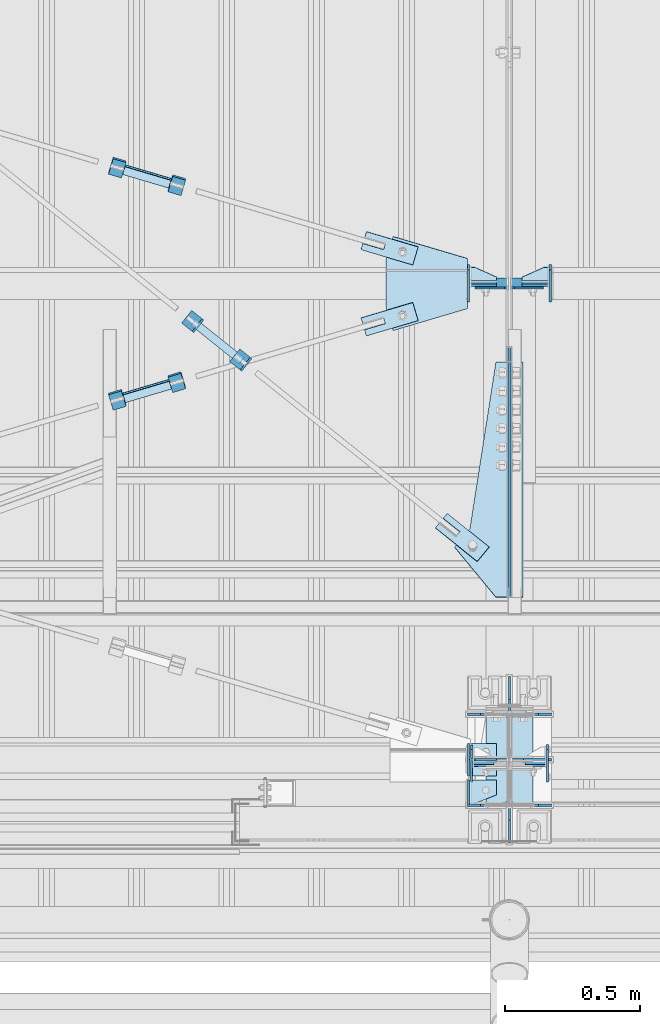
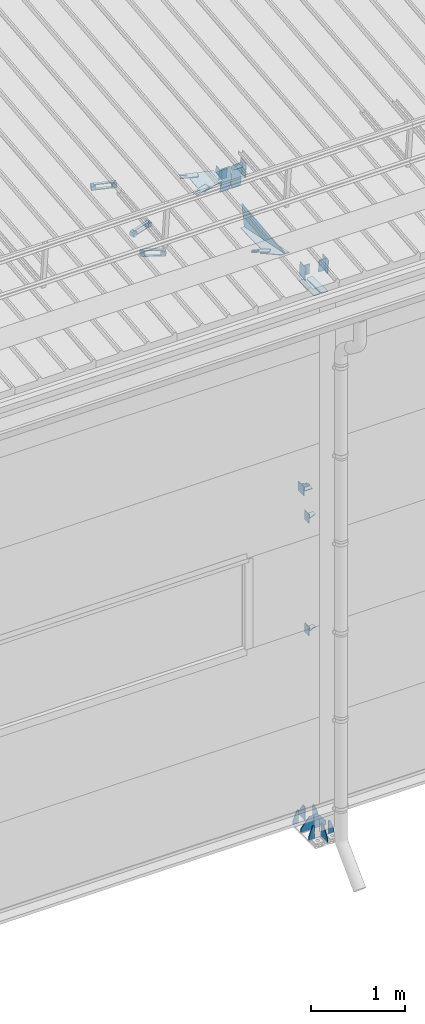
# One storey, part 147 of 709: 47 plates, 2 openings, 15 elements without a shape of their own.
"""IFC4 building model written with IfcOpenShell, lengths in millimetres."""

from ifc_helpers import new_model, si_unit, direction, frame, origin_with_axes, place, context, subcontext, project, spatial, line, indexed_curve, outline, extrude, material, element, aggregate, save


model = new_model("IFC4")

# Units and contexts
model_context = context("Model", 3, precision=0.2, world=origin_with_axes(), true_north=direction((0.0, 1.0)))
body_context = subcontext(model_context, "Body", "Model", "MODEL_VIEW")
ifc_project = project(units=[si_unit("LENGTHUNIT", "METRE", prefix="MILLI"), si_unit("AREAUNIT", "SQUARE_METRE"), si_unit("VOLUMEUNIT", "CUBIC_METRE"), si_unit("MASSUNIT", "GRAM", prefix="KILO"), si_unit("TIMEUNIT", "SECOND"), si_unit("PLANEANGLEUNIT", "RADIAN"), si_unit("SOLIDANGLEUNIT", "STERADIAN"), si_unit("THERMODYNAMICTEMPERATUREUNIT", "DEGREE_CELSIUS"), si_unit("LUMINOUSINTENSITYUNIT", "LUMEN")], contexts=[model_context])

# Site, building, storey
site_placement = place(None, origin_with_axes())
site = spatial("IfcSite", under=ifc_project, at=site_placement, CompositionType="ELEMENT")
building_placement = place(site_placement, origin_with_axes())
building = spatial("IfcBuilding", under=site, at=building_placement, Name="Undefined", CompositionType="ELEMENT")
storey_placement = place(building_placement, origin_with_axes())
storey = spatial("IfcBuildingStorey", under=building, at=storey_placement, Name="Undefined", CompositionType="ELEMENT", Elevation=0.0)

# Assembly, plates
assembly_1_placement = place(storey_placement, frame((46000.0, 173.0, -200.0), z_axis=(-1.0, 0.0, 0.0), x_axis=(0.0, 0.0, 1.0)))
assembly_1 = element("IfcElementAssembly", 1, at=assembly_1_placement, inside=storey)
ifc_material_1 = material(Name="C355-6", Category="STEEL")
plate_1_placement = place(assembly_1_placement, frame((25.0, -168.5, -87.0), z_axis=(0.0, -1.0, 0.0), x_axis=(0.0, 0.0, -1.0)))
plate_1 = element("IfcPlate", 2, at=plate_1_placement, material=ifc_material_1, ObjectType="419", context=body_context, shape_type="SolidModel", body=[
    extrude(outline(indexed_curve([(0.0, 0.0), (68.0, 0.0), (68.0, 50.0), (20.0, 175.0), (0.0, 175.0)], segments=[line(1, 2, 3, 4, 5, 1)])), frame((0.0, 0.0, 4.0), z_axis=(0.0, 0.0, 1.0), x_axis=(1.0, 0.0, 0.0)), (0.0, 0.0, -1.0), 8.0),
])
plate_2_placement = place(assembly_1_placement, frame((25.0, 168.5, -87.0), z_axis=(0.0, -1.0, 0.0), x_axis=(0.0, 0.0, -1.0)))
plate_2 = element("IfcPlate", 3, at=plate_2_placement, material=ifc_material_1, ObjectType="419", context=body_context, shape_type="SolidModel", body=[
    extrude(outline(indexed_curve([(0.0, 0.0), (68.0, 0.0), (68.0, 50.0), (20.0, 175.0), (0.0, 175.0)], segments=[line(1, 2, 3, 4, 5, 1)])), frame((0.0, 0.0, 4.0), z_axis=(0.0, 0.0, 1.0), x_axis=(1.0, 0.0, 0.0)), (0.0, 0.0, -1.0), 8.0),
])
plate_3_placement = place(assembly_1_placement, frame((25.0, 168.5, 87.0), z_axis=(0.0, 1.0, 0.0), x_axis=(0.0, 0.0, 1.0)))
plate_3 = element("IfcPlate", 4, at=plate_3_placement, material=ifc_material_1, ObjectType="419", context=body_context, shape_type="SolidModel", body=[
    extrude(outline(indexed_curve([(0.0, 0.0), (68.0, 0.0), (68.0, 50.0), (20.0, 175.0), (0.0, 175.0)], segments=[line(1, 2, 3, 4, 5, 1)])), frame((0.0, 0.0, 4.0), z_axis=(0.0, 0.0, 1.0), x_axis=(1.0, 0.0, 0.0)), (0.0, 0.0, -1.0), 8.0),
])
plate_4_placement = place(assembly_1_placement, frame((25.0, -173.0, 0.0), z_axis=(0.0, 0.0, 1.0), x_axis=(0.0, -1.0, 0.0)))
plate_4 = element("IfcPlate", 5, at=plate_4_placement, material=ifc_material_1, ObjectType="418", context=body_context, shape_type="SolidModel", body=[
    extrude(outline(indexed_curve([(0.0, 0.0), (135.0, 0.0), (135.0, 50.0), (50.0, 175.0), (0.0, 175.0)], segments=[line(1, 2, 3, 4, 5, 1)])), frame((0.0, 0.0, 4.0), z_axis=(0.0, 0.0, 1.0), x_axis=(1.0, 0.0, 0.0)), (0.0, 0.0, -1.0), 8.0),
])
plate_5_placement = place(assembly_1_placement, frame((25.0, -168.5, 87.0), z_axis=(0.0, 1.0, 0.0), x_axis=(0.0, 0.0, 1.0)))
plate_5 = element("IfcPlate", 6, at=plate_5_placement, material=ifc_material_1, ObjectType="419", context=body_context, shape_type="SolidModel", body=[
    extrude(outline(indexed_curve([(0.0, 0.0), (68.0, 0.0), (68.0, 50.0), (20.0, 175.0), (0.0, 175.0)], segments=[line(1, 2, 3, 4, 5, 1)])), frame((0.0, 0.0, 4.0), z_axis=(0.0, 0.0, 1.0), x_axis=(1.0, 0.0, 0.0)), (0.0, 0.0, -1.0), 8.0),
])
plate_6_placement = place(assembly_1_placement, frame((25.0, 0.0, -3.0), z_axis=(0.0, -1.0, 0.0), x_axis=(0.0, 0.0, -1.0)))
plate_6 = element("IfcPlate", 7, at=plate_6_placement, material=ifc_material_1, ObjectType="417", context=body_context, shape_type="SolidModel", body=[
    extrude(outline(indexed_curve([(0.0, 0.0), (152.0, 0.0), (152.0, 50.0), (50.0, 175.0), (0.0, 175.0)], segments=[line(1, 2, 3, 4, 5, 1)])), frame((0.0, 0.0, 4.0), z_axis=(0.0, 0.0, 1.0), x_axis=(1.0, 0.0, 0.0)), (0.0, 0.0, -1.0), 8.0),
])
plate_7_placement = place(assembly_1_placement, frame((25.0, 0.0, 3.0), z_axis=(0.0, 1.0, 0.0), x_axis=(0.0, 0.0, 1.0)))
plate_7 = element("IfcPlate", 8, at=plate_7_placement, material=ifc_material_1, ObjectType="417", context=body_context, shape_type="SolidModel", body=[
    extrude(outline(indexed_curve([(0.0, 0.0), (152.0, 0.0), (152.0, 50.0), (50.0, 175.0), (0.0, 175.0)], segments=[line(1, 2, 3, 4, 5, 1)])), frame((0.0, 0.0, 4.0), z_axis=(0.0, 0.0, 1.0), x_axis=(1.0, 0.0, 0.0)), (0.0, 0.0, -1.0), 8.0),
])
plate_8_placement = place(assembly_1_placement, frame((25.0, 173.0, 0.0), z_axis=(0.0, 0.0, -1.0), x_axis=(0.0, 1.0, 0.0)))
plate_8 = element("IfcPlate", 9, at=plate_8_placement, material=ifc_material_1, ObjectType="418", context=body_context, shape_type="SolidModel", body=[
    extrude(outline(indexed_curve([(0.0, 0.0), (135.0, 0.0), (135.0, 50.0), (50.0, 175.0), (0.0, 175.0)], segments=[line(1, 2, 3, 4, 5, 1)])), frame((0.0, 0.0, 4.0), z_axis=(0.0, 0.0, 1.0), x_axis=(1.0, 0.0, 0.0)), (0.0, 0.0, -1.0), 8.0),
])
plate_9_placement = place(assembly_1_placement, frame((7097.93718, 163.0, 87.0), z_axis=(-1.0, 0.0, 0.0), x_axis=(0.0, 0.0, -1.0)))
plate_9 = element("IfcPlate", 10, at=plate_9_placement, material=ifc_material_1, ObjectType="461", context=body_context, shape_type="SolidModel", body=[
    extrude(outline(indexed_curve([(0.0, 0.0), (68.0, 0.0), (83.0, 15.0), (83.0, 311.0), (68.0, 326.0), (0.0, 326.0)], segments=[line(1, 2, 3, 4, 5, 6, 1)])), frame((0.0, 0.0, 4.0), z_axis=(0.0, 0.0, 1.0), x_axis=(1.0, 0.0, 0.0)), (0.0, 0.0, -1.0), 8.0),
])
plate_10_placement = place(assembly_1_placement, frame((7097.93718, -163.0, -87.0), z_axis=(-1.0, 0.0, 0.0), x_axis=(0.0, 0.0, 1.0)))
plate_10 = element("IfcPlate", 11, at=plate_10_placement, material=ifc_material_1, ObjectType="461", context=body_context, shape_type="SolidModel", body=[
    extrude(outline(indexed_curve([(0.0, 0.0), (68.0, 0.0), (83.0, 15.0), (83.0, 311.0), (68.0, 326.0), (0.0, 326.0)], segments=[line(1, 2, 3, 4, 5, 6, 1)])), frame((0.0, 0.0, 4.0), z_axis=(0.0, 0.0, 1.0), x_axis=(1.0, 0.0, 0.0)), (0.0, 0.0, -1.0), 8.0),
])
aggregate(assembly_1, [plate_1, plate_2, plate_3, plate_4, plate_5, plate_6, plate_7, plate_8, plate_9, plate_10])

assembly_2_placement = place(storey_placement, frame((46000.0, 346.0, 7089.70002), z_axis=(1.0, 0.0, 0.0), x_axis=(0.0, 0.9950371902, 0.099503719)))
assembly_2 = element("IfcElementAssembly", 12, at=assembly_2_placement, inside=storey)
plate_11_placement = place(assembly_2_placement, frame((1597.88359, 163.0, 127.0), z_axis=(-1.0, 0.0, 0.0), x_axis=(0.0, 0.0, -1.0)))
plate_11 = element("IfcPlate", 13, at=plate_11_placement, material=ifc_material_1, ObjectType="585", context=body_context, shape_type="SolidModel", body=[
    extrude(outline(indexed_curve([(0.0, 0.0), (108.0, 0.0), (123.0, 15.0), (123.0, 311.0), (108.0, 326.0), (0.0, 326.0)], segments=[line(1, 2, 3, 4, 5, 6, 1)])), frame((0.0, 0.0, 4.0), z_axis=(0.0, 0.0, 1.0), x_axis=(1.0, 0.0, 0.0)), (0.0, 0.0, -1.0), 8.0),
])
plate_12_placement = place(assembly_2_placement, frame((1597.88359, 163.0, -127.0), z_axis=(1.0, 0.0, 0.0), x_axis=(0.0, 0.0, 1.0)))
plate_12 = element("IfcPlate", 14, at=plate_12_placement, material=ifc_material_1, ObjectType="585", context=body_context, shape_type="SolidModel", body=[
    extrude(outline(indexed_curve([(0.0, 0.0), (108.0, 0.0), (123.0, 15.0), (123.0, 311.0), (108.0, 326.0), (0.0, 326.0)], segments=[line(1, 2, 3, 4, 5, 6, 1)])), frame((0.0, 0.0, 4.0), z_axis=(0.0, 0.0, 1.0), x_axis=(1.0, 0.0, 0.0)), (0.0, 0.0, -1.0), 8.0),
])
plate_13_placement = place(assembly_2_placement, frame((412.62035, -176.8248, 50.0), z_axis=(0.2927142719, 0.9561999556, 0.0), x_axis=(0.9561999556, -0.2927142719, 0.0)))
plate_13 = element("IfcPlate", 15, at=plate_13_placement, material=ifc_material_1, ObjectType="489", context=body_context, shape_type="SolidModel", body=[
    extrude(outline(indexed_curve([(0.0, 0.0), (887.65935, 0.0), (887.65935, 100.0), (259.05365, 196.23068), (189.37305, 253.1922), (0.0, 100.0)], segments=[line(1, 2, 3, 4, 5, 6, 1)])), frame((0.0, 0.0, 4.0), z_axis=(0.0, 0.0, 1.0), x_axis=(1.0, 0.0, 0.0)), (0.0, 0.0, -1.0), 8.0),
])
plate_14_placement = place(assembly_2_placement, frame((1342.111, -173.0, 0.0), z_axis=(0.0, 0.0, 1.0), x_axis=(-1.0, 0.0, 0.0)))
plate_14 = element("IfcPlate", 16, at=plate_14_placement, material=ifc_material_1, ObjectType="449", context=body_context, shape_type="SolidModel", body=[
    extrude(outline(indexed_curve([(0.0, 0.0), (928.3198, 0.0), (79.53997, 259.83056)], segments=[line(1, 2, 3, 1)])), frame((0.0, 0.0, 6.0), z_axis=(0.0, 0.0, 1.0), x_axis=(1.0, 0.0, 0.0)), (0.0, 0.0, -1.0), 12.0),
])
aggregate(assembly_2, [plate_11, plate_12, plate_13, plate_14])

# Assembly, plate
assembly_3_placement = place(storey_placement, frame((44916.07962, 1724.40956, 6772.92001), z_axis=(-0.625451877, -0.7802627439, 1e-10), x_axis=(0.7742288439, -0.6206151549, 0.124123031)))
assembly_3 = element("IfcElementAssembly", 17, at=assembly_3_placement, inside=storey)
plate_15_placement = place(assembly_3_placement, frame((1074.34134, 5.35577, 34.5878), z_axis=(1e-10, 0.9882227648, -0.1530221135), x_axis=(1.0, 0.0, 0.0)))
plate_15 = element("IfcPlate", 18, at=plate_15_placement, material=ifc_material_1, ObjectType="490", context=body_context, shape_type="SolidModel", body=[
    extrude(outline(indexed_curve([(0.0, 0.0), (200.0, 0.0), (200.0, 70.0), (0.0, 70.0), (0.0, 46.0), (80.0, 46.0), (80.0, 24.0), (0.0, 24.0)], segments=[line(1, 2, 3, 4, 5, 6, 7, 8, 1)])), frame((0.0, 0.0, 4.0), z_axis=(0.0, 0.0, 1.0), x_axis=(1.0, 0.0, 0.0)), (0.0, 0.0, -1.0), 8.0),
])
aggregate(assembly_3, [plate_15])

# Assembly, plates
assembly_4_placement = place(storey_placement, frame((44983.44692, 1631.95992, 6816.96217), z_axis=(-0.7742288439, 0.6206151548, -0.1241230313), x_axis=(0.625451877, 0.780262744, 0.0)))
assembly_4 = element("IfcElementAssembly", 19, at=assembly_4_placement, inside=storey)
ifc_material_2 = material(Name="Steel_Undefined", Category="STEEL")
plate_16_placement = place(assembly_4_placement, origin_with_axes())
plate_16 = element("IfcPlate", 20, at=plate_16_placement, material=ifc_material_2, ObjectType="482", context=body_context, shape_type="SolidModel", body=[
    extrude(outline(indexed_curve([(0.0, 0.0), (60.0, 0.0), (60.0, 60.0), (0.0, 60.0)], segments=[line(1, 2, 3, 4, 1)])), frame((0.0, 0.0, 25.0), z_axis=(0.0, 0.0, 1.0), x_axis=(1.0, 0.0, 0.0)), (0.0, 0.0, -1.0), 50.0),
])
plate_17_placement = place(assembly_4_placement, frame((15.0, -6.0, 230.0), z_axis=(0.0, 1.0, 0.0), x_axis=(1.0, 0.0, 0.0)))
plate_17 = element("IfcPlate", 21, at=plate_17_placement, material=ifc_material_2, ObjectType="484", context=body_context, shape_type="SolidModel", body=[
    extrude(outline(indexed_curve([(0.0, 0.0), (30.0, 0.0), (30.0, 230.0), (0.0, 230.0)], segments=[line(1, 2, 3, 4, 1)])), frame((0.0, 0.0, 6.0), z_axis=(0.0, 0.0, 1.0), x_axis=(1.0, 0.0, 0.0)), (0.0, 0.0, -1.0), 12.0),
])
plate_18_placement = place(assembly_4_placement, frame((15.0, 66.0, 230.0), z_axis=(0.0, 1.0, 0.0), x_axis=(1.0, 0.0, 0.0)))
plate_18 = element("IfcPlate", 22, at=plate_18_placement, material=ifc_material_2, ObjectType="484", context=body_context, shape_type="SolidModel", body=[
    extrude(outline(indexed_curve([(0.0, 0.0), (30.0, 0.0), (30.0, 230.0), (0.0, 230.0)], segments=[line(1, 2, 3, 4, 1)])), frame((0.0, 0.0, 6.0), z_axis=(0.0, 0.0, 1.0), x_axis=(1.0, 0.0, 0.0)), (0.0, 0.0, -1.0), 12.0),
])
plate_19_placement = place(assembly_4_placement, frame((0.0, 0.0, 230.0), z_axis=(0.0, 0.0, 1.0), x_axis=(1.0, 0.0, 0.0)))
plate_19 = element("IfcPlate", 23, at=plate_19_placement, material=ifc_material_2, ObjectType="483", context=body_context, shape_type="SolidModel", body=[
    extrude(outline(indexed_curve([(0.0, 0.0), (60.0, 0.0), (60.0, 60.0), (0.0, 60.0)], segments=[line(1, 2, 3, 4, 1)])), frame((0.0, 0.0, 25.0), z_axis=(0.0, 0.0, 1.0), x_axis=(1.0, 0.0, 0.0)), (0.0, 0.0, -1.0), 50.0),
])
aggregate(assembly_4, [plate_16, plate_17, plate_18, plate_19])

assembly_5_placement = place(storey_placement, frame((40000.0, 50.0, 2550.0), z_axis=(0.0, 0.0, -1.0), x_axis=(1.0, 0.0, 0.0)))
assembly_5 = element("IfcElementAssembly", 24, at=assembly_5_placement, inside=storey)
plate_20_placement = place(assembly_5_placement, frame((5849.0, 47.0, -60.0), z_axis=(-1.0, 0.0, 0.0), x_axis=(0.0, -1.0, 0.0)))
plate_20 = element("IfcPlate", 25, at=plate_20_placement, material=ifc_material_1, ObjectType="501", context=body_context, shape_type="SolidModel", body=[
    extrude(outline(indexed_curve([(0.0, 0.0), (94.0, 0.0), (94.0, 120.0), (0.0, 120.0)], segments=[line(1, 2, 3, 4, 1)])), frame((0.0, 0.0, 4.0), z_axis=(0.0, 0.0, 1.0), x_axis=(1.0, 0.0, 0.0)), (0.0, 0.0, -1.0), 8.0),
])
plate_21_placement = place(assembly_5_placement, frame((5853.0, 47.0, 0.0), z_axis=(0.0, 0.0, 1.0), x_axis=(0.0, -1.0, 0.0)))
plate_21 = element("IfcPlate", 26, at=plate_21_placement, material=ifc_material_1, ObjectType="502", context=body_context, shape_type="SolidModel", body=[
    extrude(outline(indexed_curve([(0.0, 0.0), (94.0, 0.0), (94.0, 100.0), (40.0, 100.0), (0.0, 0.0)], segments=[line(1, 2, 3, 4, 5, 1)])), frame((0.0, 0.0, 4.0), z_axis=(0.0, 0.0, 1.0), x_axis=(1.0, 0.0, 0.0)), (0.0, 0.0, -1.0), 8.0),
])
aggregate(assembly_5, [plate_20, plate_21])

assembly_6_placement = place(storey_placement, frame((40000.0, 50.0, 4020.0), z_axis=(0.0, 0.0, -1.0), x_axis=(1.0, 0.0, 0.0)))
assembly_6 = element("IfcElementAssembly", 27, at=assembly_6_placement, inside=storey)
plate_22_placement = place(assembly_6_placement, frame((5853.0, 47.0, 0.0), z_axis=(0.0, 0.0, 1.0), x_axis=(0.0, -1.0, 0.0)))
plate_22 = element("IfcPlate", 28, at=plate_22_placement, material=ifc_material_1, ObjectType="502", context=body_context, shape_type="SolidModel", body=[
    extrude(outline(indexed_curve([(0.0, 0.0), (94.0, 0.0), (94.0, 100.0), (40.0, 100.0), (0.0, 0.0)], segments=[line(1, 2, 3, 4, 5, 1)])), frame((0.0, 0.0, 4.0), z_axis=(0.0, 0.0, 1.0), x_axis=(1.0, 0.0, 0.0)), (0.0, 0.0, -1.0), 8.0),
])
plate_23_placement = place(assembly_6_placement, frame((5849.0, 47.0, -60.0), z_axis=(-1.0, 0.0, 0.0), x_axis=(0.0, -1.0, 0.0)))
plate_23 = element("IfcPlate", 29, at=plate_23_placement, material=ifc_material_1, ObjectType="501", context=body_context, shape_type="SolidModel", body=[
    extrude(outline(indexed_curve([(0.0, 0.0), (94.0, 0.0), (94.0, 120.0), (0.0, 120.0)], segments=[line(1, 2, 3, 4, 1)])), frame((0.0, 0.0, 4.0), z_axis=(0.0, 0.0, 1.0), x_axis=(1.0, 0.0, 0.0)), (0.0, 0.0, -1.0), 8.0),
])
aggregate(assembly_6, [plate_22, plate_23])

assembly_7_placement = place(storey_placement, frame((40000.0, 173.0, 4310.0), z_axis=(0.0, 0.0, -1.0), x_axis=(1.0, 0.0, 0.0)))
assembly_7 = element("IfcElementAssembly", 30, at=assembly_7_placement, inside=storey)
plate_24_placement = place(assembly_7_placement, frame((5953.0, 0.0, -60.0), z_axis=(0.0, -1.0, 0.0), x_axis=(0.0, 0.0, 1.0)))
plate_24 = element("IfcPlate", 31, at=plate_24_placement, material=ifc_material_1, ObjectType="508", context=body_context, shape_type="SolidModel", body=[
    extrude(outline(indexed_curve([(0.0, 80.0), (36.0, 0.0), (56.0, 0.0), (56.0, 90.0), (46.0, 100.0), (0.0, 100.0)], segments=[line(1, 2, 3, 4, 5, 6, 1)])), frame((0.0, 0.0, 4.0), z_axis=(0.0, 0.0, 1.0), x_axis=(1.0, 0.0, 0.0)), (0.0, 0.0, -1.0), 8.0),
])
plate_25_placement = place(assembly_7_placement, frame((5953.0, -60.0, 0.0), z_axis=(0.0, 0.0, 1.0), x_axis=(0.0, 1.0, 0.0)))
plate_25 = element("IfcPlate", 32, at=plate_25_placement, material=ifc_material_1, ObjectType="507", context=body_context, shape_type="SolidModel", body=[
    extrude(outline(indexed_curve([(0.0, 0.0), (120.0, 0.0), (120.0, 100.0), (0.0, 100.0)], segments=[line(1, 2, 3, 4, 1)])), frame((0.0, 0.0, 4.0), z_axis=(0.0, 0.0, 1.0), x_axis=(1.0, 0.0, 0.0)), (0.0, 0.0, -1.0), 8.0),
])
plate_26_placement = place(assembly_7_placement, frame((5849.0, -60.0, 60.0), z_axis=(1.0, 0.0, 0.0), x_axis=(0.0, 0.0, -1.0)))
plate_26 = element("IfcPlate", 33, at=plate_26_placement, material=ifc_material_1, ObjectType="506", context=body_context, shape_type="SolidModel", body=[
    extrude(outline(indexed_curve([(0.0, 0.0), (120.0, 0.0), (120.0, 120.0), (0.0, 120.0)], segments=[line(1, 2, 3, 4, 1)])), frame((0.0, 0.0, 4.0), z_axis=(0.0, 0.0, 1.0), x_axis=(1.0, 0.0, 0.0)), (0.0, 0.0, -1.0), 8.0),
])
aggregate(assembly_7, [plate_24, plate_25, plate_26])

# Assembly, plate, voiding feature
assembly_8_placement = place(storey_placement, frame((44658.15773, 1538.51229, 7290.35524), z_axis=(0.2852311229, -0.9537021177, -0.0953702118), x_axis=(0.9584587662, 0.2838155751, 0.028381558)))
assembly_8 = element("IfcElementAssembly", 34, at=assembly_8_placement, inside=storey)
plate_27_placement = place(assembly_8_placement, frame((1036.9749, 0.0, 35.0), z_axis=(0.0, 1.0, 0.0), x_axis=(0.0, 0.0, -1.0)))
plate_27 = element("IfcPlate", 35, at=plate_27_placement, material=ifc_material_1, ObjectType="574", context=body_context, shape_type="SolidModel", body=[
    extrude(outline(indexed_curve([(0.0, 0.0), (70.0, 0.0), (70.0, 200.0), (0.0, 200.0)], segments=[line(1, 2, 3, 4, 1)])), frame((0.0, 0.0, 4.0), z_axis=(0.0, 0.0, 1.0), x_axis=(1.0, 0.0, 0.0)), (0.0, 0.0, -1.0), 8.0),
])
voiding_feature_1_placement = place(plate_27_placement, frame((24.0, 120.0, 0.0), z_axis=(0.0, 0.0, 1.0), x_axis=(1.0, 0.0, 0.0)))
element("IfcVoidingFeature", 36, at=voiding_feature_1_placement, cuts=plate_27, Name="PLATE", PredefinedType="HOLE", context=body_context, shape_type="SolidModel", body=[
    extrude(outline(indexed_curve([(0.0, 0.0), (22.0, 0.0), (22.0, 85.0), (0.0, 85.0)], segments=[line(1, 2, 3, 4, 1)])), frame((0.0, 0.0, 6.5), z_axis=(0.0, 0.0, 1.0), x_axis=(1.0, 0.0, 0.0)), (0.0, 0.0, -1.0), 13.0),
])
aggregate(assembly_8, [plate_27])

# Assembly, plates
assembly_9_placement = place(storey_placement, frame((44776.93742, 1539.5549, 7320.60913), z_axis=(-0.9584587662, -0.2838155751, -0.0283815575), x_axis=(-0.2852311229, 0.9537021176, 0.095370212)))
assembly_9 = element("IfcElementAssembly", 37, at=assembly_9_placement, inside=storey)
plate_28_placement = place(assembly_9_placement, frame((15.0, -6.0, 230.0), z_axis=(0.0, 1.0, 0.0), x_axis=(1.0, 0.0, 0.0)))
plate_28 = element("IfcPlate", 38, at=plate_28_placement, material=ifc_material_2, ObjectType="484", context=body_context, shape_type="SolidModel", body=[
    extrude(outline(indexed_curve([(0.0, 0.0), (30.0, 0.0), (30.0, 230.0), (0.0, 230.0)], segments=[line(1, 2, 3, 4, 1)])), frame((0.0, 0.0, 6.0), z_axis=(0.0, 0.0, 1.0), x_axis=(1.0, 0.0, 0.0)), (0.0, 0.0, -1.0), 12.0),
])
plate_29_placement = place(assembly_9_placement, frame((0.0, 0.0, 230.0), z_axis=(0.0, 0.0, 1.0), x_axis=(1.0, 0.0, 0.0)))
plate_29 = element("IfcPlate", 39, at=plate_29_placement, material=ifc_material_2, ObjectType="483", context=body_context, shape_type="SolidModel", body=[
    extrude(outline(indexed_curve([(0.0, 0.0), (60.0, 0.0), (60.0, 60.0), (0.0, 60.0)], segments=[line(1, 2, 3, 4, 1)])), frame((0.0, 0.0, 25.0), z_axis=(0.0, 0.0, 1.0), x_axis=(1.0, 0.0, 0.0)), (0.0, 0.0, -1.0), 50.0),
])
plate_30_placement = place(assembly_9_placement, frame((15.0, 66.0, 230.0), z_axis=(0.0, 1.0, 0.0), x_axis=(1.0, 0.0, 0.0)))
plate_30 = element("IfcPlate", 40, at=plate_30_placement, material=ifc_material_2, ObjectType="484", context=body_context, shape_type="SolidModel", body=[
    extrude(outline(indexed_curve([(0.0, 0.0), (30.0, 0.0), (30.0, 230.0), (0.0, 230.0)], segments=[line(1, 2, 3, 4, 1)])), frame((0.0, 0.0, 6.0), z_axis=(0.0, 0.0, 1.0), x_axis=(1.0, 0.0, 0.0)), (0.0, 0.0, -1.0), 12.0),
])
plate_31_placement = place(assembly_9_placement, origin_with_axes())
plate_31 = element("IfcPlate", 41, at=plate_31_placement, material=ifc_material_2, ObjectType="482", context=body_context, shape_type="SolidModel", body=[
    extrude(outline(indexed_curve([(0.0, 0.0), (60.0, 0.0), (60.0, 60.0), (0.0, 60.0)], segments=[line(1, 2, 3, 4, 1)])), frame((0.0, 0.0, 25.0), z_axis=(0.0, 0.0, 1.0), x_axis=(1.0, 0.0, 0.0)), (0.0, 0.0, -1.0), 50.0),
])
aggregate(assembly_9, [plate_28, plate_29, plate_30, plate_31])

# Assembly, plate, voiding feature
assembly_10_placement = place(storey_placement, frame((44658.15773, 2333.1959, 7369.82361), z_axis=(-0.2852311229, -0.9537021177, -0.0953702118), x_axis=(0.9584587662, -0.2838155751, -0.028381558)))
assembly_10 = element("IfcElementAssembly", 42, at=assembly_10_placement, inside=storey)
plate_32_placement = place(assembly_10_placement, frame((1036.9749, 0.0, 35.0), z_axis=(0.0, 1.0, 0.0), x_axis=(0.0, 0.0, -1.0)))
plate_32 = element("IfcPlate", 43, at=plate_32_placement, material=ifc_material_1, ObjectType="574", context=body_context, shape_type="SolidModel", body=[
    extrude(outline(indexed_curve([(0.0, 0.0), (70.0, 0.0), (70.0, 200.0), (0.0, 200.0)], segments=[line(1, 2, 3, 4, 1)])), frame((0.0, 0.0, 4.0), z_axis=(0.0, 0.0, 1.0), x_axis=(1.0, 0.0, 0.0)), (0.0, 0.0, -1.0), 8.0),
])
voiding_feature_2_placement = place(plate_32_placement, frame((24.0, 120.0, 0.0), z_axis=(0.0, 0.0, 1.0), x_axis=(1.0, 0.0, 0.0)))
element("IfcVoidingFeature", 44, at=voiding_feature_2_placement, cuts=plate_32, Name="PLATE", PredefinedType="HOLE", context=body_context, shape_type="SolidModel", body=[
    extrude(outline(indexed_curve([(0.0, 0.0), (22.0, 0.0), (22.0, 85.0), (0.0, 85.0)], segments=[line(1, 2, 3, 4, 1)])), frame((0.0, 0.0, 6.5), z_axis=(0.0, 0.0, 1.0), x_axis=(1.0, 0.0, 0.0)), (0.0, 0.0, -1.0), 13.0),
])
aggregate(assembly_10, [plate_32])

# Assembly, plates
assembly_11_placement = place(storey_placement, frame((44759.82355, 2268.96093, 7393.54974), z_axis=(-0.9584587662, 0.2838155751, 0.0283815575), x_axis=(0.2852311229, 0.9537021176, 0.095370212)))
assembly_11 = element("IfcElementAssembly", 45, at=assembly_11_placement, inside=storey)
plate_33_placement = place(assembly_11_placement, frame((0.0, 0.0, 230.0), z_axis=(0.0, 0.0, 1.0), x_axis=(1.0, 0.0, 0.0)))
plate_33 = element("IfcPlate", 46, at=plate_33_placement, material=ifc_material_2, ObjectType="483", context=body_context, shape_type="SolidModel", body=[
    extrude(outline(indexed_curve([(0.0, 0.0), (60.0, 0.0), (60.0, 60.0), (0.0, 60.0)], segments=[line(1, 2, 3, 4, 1)])), frame((0.0, 0.0, 25.0), z_axis=(0.0, 0.0, 1.0), x_axis=(1.0, 0.0, 0.0)), (0.0, 0.0, -1.0), 50.0),
])
plate_34_placement = place(assembly_11_placement, origin_with_axes())
plate_34 = element("IfcPlate", 47, at=plate_34_placement, material=ifc_material_2, ObjectType="482", context=body_context, shape_type="SolidModel", body=[
    extrude(outline(indexed_curve([(0.0, 0.0), (60.0, 0.0), (60.0, 60.0), (0.0, 60.0)], segments=[line(1, 2, 3, 4, 1)])), frame((0.0, 0.0, 25.0), z_axis=(0.0, 0.0, 1.0), x_axis=(1.0, 0.0, 0.0)), (0.0, 0.0, -1.0), 50.0),
])
plate_35_placement = place(assembly_11_placement, frame((15.0, -6.0, 230.0), z_axis=(0.0, 1.0, 0.0), x_axis=(1.0, 0.0, 0.0)))
plate_35 = element("IfcPlate", 48, at=plate_35_placement, material=ifc_material_2, ObjectType="484", context=body_context, shape_type="SolidModel", body=[
    extrude(outline(indexed_curve([(0.0, 0.0), (30.0, 0.0), (30.0, 230.0), (0.0, 230.0)], segments=[line(1, 2, 3, 4, 1)])), frame((0.0, 0.0, 6.0), z_axis=(0.0, 0.0, 1.0), x_axis=(1.0, 0.0, 0.0)), (0.0, 0.0, -1.0), 12.0),
])
plate_36_placement = place(assembly_11_placement, frame((15.0, 66.0, 230.0), z_axis=(0.0, 1.0, 0.0), x_axis=(1.0, 0.0, 0.0)))
plate_36 = element("IfcPlate", 49, at=plate_36_placement, material=ifc_material_2, ObjectType="484", context=body_context, shape_type="SolidModel", body=[
    extrude(outline(indexed_curve([(0.0, 0.0), (30.0, 0.0), (30.0, 230.0), (0.0, 230.0)], segments=[line(1, 2, 3, 4, 1)])), frame((0.0, 0.0, 6.0), z_axis=(0.0, 0.0, 1.0), x_axis=(1.0, 0.0, 0.0)), (0.0, 0.0, -1.0), 12.0),
])
aggregate(assembly_11, [plate_33, plate_34, plate_35, plate_36])

assembly_12_placement = place(storey_placement, frame((40000.0, 158.95533, 7154.40952), z_axis=(0.0, 0.9950371902, 0.099503719), x_axis=(1.0, 0.0, 0.0)))
assembly_12 = element("IfcElementAssembly", 50, at=assembly_12_placement, inside=storey)
plate_37_placement = place(assembly_12_placement, frame((5859.0, -87.0, 60.0), z_axis=(1.0, 0.0, 0.0), x_axis=(0.0, 0.0, -1.0)))
plate_37 = element("IfcPlate", 51, at=plate_37_placement, material=ifc_material_1, ObjectType="596", context=body_context, shape_type="SolidModel", body=[
    extrude(outline(indexed_curve([(0.0, 0.0), (120.0, 0.0), (120.0, 174.0), (0.0, 174.0)], segments=[line(1, 2, 3, 4, 1)])), frame((0.0, 0.0, 4.0), z_axis=(0.0, 0.0, 1.0), x_axis=(1.0, 0.0, 0.0)), (0.0, 0.0, -1.0), 8.0),
])
plate_38_placement = place(assembly_12_placement, frame((5943.0, 72.0, 0.0), z_axis=(0.0, 0.0, 1.0), x_axis=(-1.0, 0.0, 0.0)))
plate_38 = element("IfcPlate", 52, at=plate_38_placement, material=ifc_material_1, ObjectType="597", context=body_context, shape_type="SolidModel", body=[
    extrude(outline(indexed_curve([(0.0, 0.0), (80.0, 0.0), (80.0, 144.0), (0.0, 144.0)], segments=[line(1, 2, 3, 4, 1)])), frame((0.0, 0.0, 4.0), z_axis=(0.0, 0.0, 1.0), x_axis=(1.0, 0.0, 0.0)), (0.0, 0.0, -1.0), 8.0),
])
aggregate(assembly_12, [plate_37, plate_38])

assembly_13_placement = place(storey_placement, frame((46000.0, 159.95037, 7144.45915), z_axis=(0.0, 0.9950371902, 0.099503719), x_axis=(1.0, 0.0, 0.0)))
assembly_13 = element("IfcElementAssembly", 53, at=assembly_13_placement, inside=storey)
plate_39_placement = place(assembly_13_placement, frame((57.0, -82.0, 0.0), z_axis=(0.0, 0.0, 1.0), x_axis=(1.0, 0.0, 0.0)))
plate_39 = element("IfcPlate", 54, at=plate_39_placement, material=ifc_material_1, ObjectType="583", context=body_context, shape_type="SolidModel", body=[
    extrude(outline(indexed_curve([(0.0, 0.0), (80.0, 0.0), (80.0, 164.0), (0.0, 164.0)], segments=[line(1, 2, 3, 4, 1)])), frame((0.0, 0.0, 4.0), z_axis=(0.0, 0.0, 1.0), x_axis=(1.0, 0.0, 0.0)), (0.0, 0.0, -1.0), 8.0),
])
plate_40_placement = place(assembly_13_placement, frame((141.0, -97.0, -60.0), z_axis=(-1.0, 0.0, 0.0), x_axis=(0.0, 0.0, 1.0)))
plate_40 = element("IfcPlate", 55, at=plate_40_placement, material=ifc_material_1, ObjectType="582", context=body_context, shape_type="SolidModel", body=[
    extrude(outline(indexed_curve([(0.0, 0.0), (120.0, 0.0), (120.0, 194.0), (0.0, 194.0)], segments=[line(1, 2, 3, 4, 1)])), frame((0.0, 0.0, 4.0), z_axis=(0.0, 0.0, 1.0), x_axis=(1.0, 0.0, 0.0)), (0.0, 0.0, -1.0), 8.0),
])
aggregate(assembly_13, [plate_39, plate_40])

assembly_14_placement = place(storey_placement, frame((40000.0, 1936.65012, 7322.12913), z_axis=(0.0, 0.9950371902, 0.099503719), x_axis=(1.0, 0.0, 0.0)))
assembly_14 = element("IfcElementAssembly", 56, at=assembly_14_placement, inside=storey)
plate_41_placement = place(assembly_14_placement, frame((5953.0, 0.0, 60.0), z_axis=(0.0, -1.0, 0.0), x_axis=(-1.0, 0.0, 0.0)))
plate_41 = element("IfcPlate", 57, at=plate_41_placement, material=ifc_material_1, ObjectType="588", context=body_context, shape_type="SolidModel", body=[
    extrude(outline(indexed_curve([(0.0, 36.0), (80.0, 0.0), (100.0, 0.0), (100.0, 56.0), (0.0, 56.0)], segments=[line(1, 2, 3, 4, 5, 1)])), frame((0.0, 0.0, 4.0), z_axis=(0.0, 0.0, 1.0), x_axis=(1.0, 0.0, 0.0)), (0.0, 0.0, -1.0), 8.0),
])
plate_42_placement = place(assembly_14_placement, frame((5849.0, -98.0, 60.0), z_axis=(1.0, 0.0, 0.0), x_axis=(0.0, 0.0, -1.0)))
plate_42 = element("IfcPlate", 58, at=plate_42_placement, material=ifc_material_1, ObjectType="586", context=body_context, shape_type="SolidModel", body=[
    extrude(outline(indexed_curve([(0.0, 0.0), (120.0, 0.0), (120.0, 196.0), (0.0, 196.0)], segments=[line(1, 2, 3, 4, 1)])), frame((0.0, 0.0, 4.0), z_axis=(0.0, 0.0, 1.0), x_axis=(1.0, 0.0, 0.0)), (0.0, 0.0, -1.0), 8.0),
])
plate_43_placement = place(assembly_14_placement, frame((5953.0, 65.0, 0.0), z_axis=(0.0, 0.0, 1.0), x_axis=(-1.0, 0.0, 0.0)))
plate_43 = element("IfcPlate", 59, at=plate_43_placement, material=ifc_material_1, ObjectType="587", context=body_context, shape_type="SolidModel", body=[
    extrude(outline(indexed_curve([(0.0, 0.0), (100.0, 0.0), (100.0, 130.0), (0.0, 130.0)], segments=[line(1, 2, 3, 4, 1)])), frame((0.0, 0.0, 4.0), z_axis=(0.0, 0.0, 1.0), x_axis=(1.0, 0.0, 0.0)), (0.0, 0.0, -1.0), 8.0),
])
plate_44_placement = place(assembly_14_placement, frame((5845.00055, 0.0, -93.07721), z_axis=(0.0, -1.0, 0.0), x_axis=(0.0, 0.0, 1.0)))
plate_44 = element("IfcPlate", 60, at=plate_44_placement, material=ifc_material_1, ObjectType="576", context=body_context, shape_type="SolidModel", body=[
    extrude(outline(indexed_curve([(0.0, 0.0), (186.15442, 0.0), (268.27702, 275.95562), (182.01573, 301.62642), (4.13868, 301.62642), (-82.1226, 275.95562)], segments=[line(1, 2, 3, 4, 5, 6, 1)])), frame((0.0, 0.0, 4.0), z_axis=(0.0, 0.0, 1.0), x_axis=(1.0, 0.0, 0.0)), (0.0, 0.0, -1.0), 8.0),
])
aggregate(assembly_14, [plate_41, plate_42, plate_43, plate_44])

assembly_15_placement = place(storey_placement, frame((46000.0, 1936.65012, 7322.12913), z_axis=(0.0, 0.9950371902, 0.099503719), x_axis=(1.0, 0.0, 0.0)))
assembly_15 = element("IfcElementAssembly", 61, at=assembly_15_placement, inside=storey)
plate_45_placement = place(assembly_15_placement, frame((47.0, 0.0, 60.0), z_axis=(0.0, 1.0, 0.0), x_axis=(1.0, 0.0, 0.0)))
plate_45 = element("IfcPlate", 62, at=plate_45_placement, material=ifc_material_1, ObjectType="588", context=body_context, shape_type="SolidModel", body=[
    extrude(outline(indexed_curve([(0.0, 36.0), (80.0, 0.0), (100.0, 0.0), (100.0, 56.0), (0.0, 56.0)], segments=[line(1, 2, 3, 4, 5, 1)])), frame((0.0, 0.0, 4.0), z_axis=(0.0, 0.0, 1.0), x_axis=(1.0, 0.0, 0.0)), (0.0, 0.0, -1.0), 8.0),
])
plate_46_placement = place(assembly_15_placement, frame((47.0, -65.0, 0.0), z_axis=(0.0, 0.0, 1.0), x_axis=(1.0, 0.0, 0.0)))
plate_46 = element("IfcPlate", 63, at=plate_46_placement, material=ifc_material_1, ObjectType="587", context=body_context, shape_type="SolidModel", body=[
    extrude(outline(indexed_curve([(0.0, 0.0), (100.0, 0.0), (100.0, 130.0), (0.0, 130.0)], segments=[line(1, 2, 3, 4, 1)])), frame((0.0, 0.0, 4.0), z_axis=(0.0, 0.0, 1.0), x_axis=(1.0, 0.0, 0.0)), (0.0, 0.0, -1.0), 8.0),
])
plate_47_placement = place(assembly_15_placement, frame((151.0, -98.0, -60.0), z_axis=(-1.0, 0.0, 0.0), x_axis=(0.0, 0.0, 1.0)))
plate_47 = element("IfcPlate", 64, at=plate_47_placement, material=ifc_material_1, ObjectType="586", context=body_context, shape_type="SolidModel", body=[
    extrude(outline(indexed_curve([(0.0, 0.0), (120.0, 0.0), (120.0, 196.0), (0.0, 196.0)], segments=[line(1, 2, 3, 4, 1)])), frame((0.0, 0.0, 4.0), z_axis=(0.0, 0.0, 1.0), x_axis=(1.0, 0.0, 0.0)), (0.0, 0.0, -1.0), 8.0),
])
aggregate(assembly_15, [plate_45, plate_46, plate_47])

save(model, "model.ifc")
